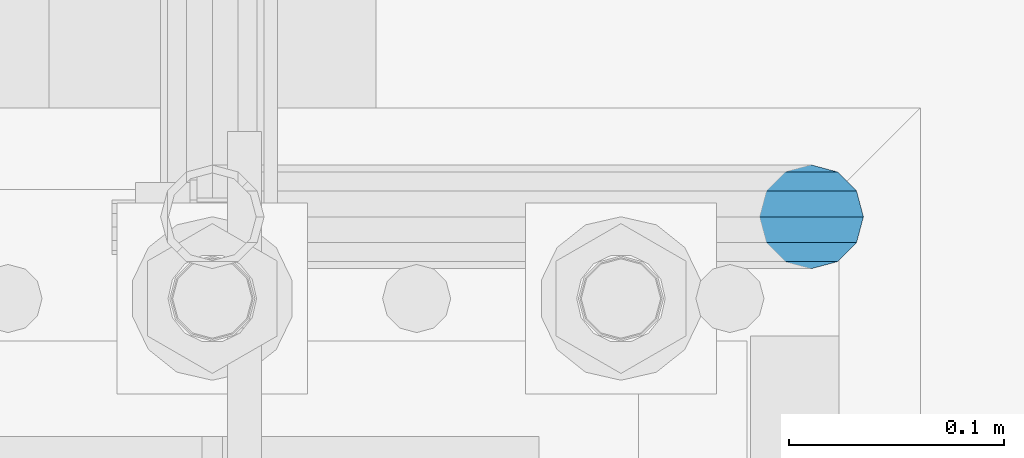
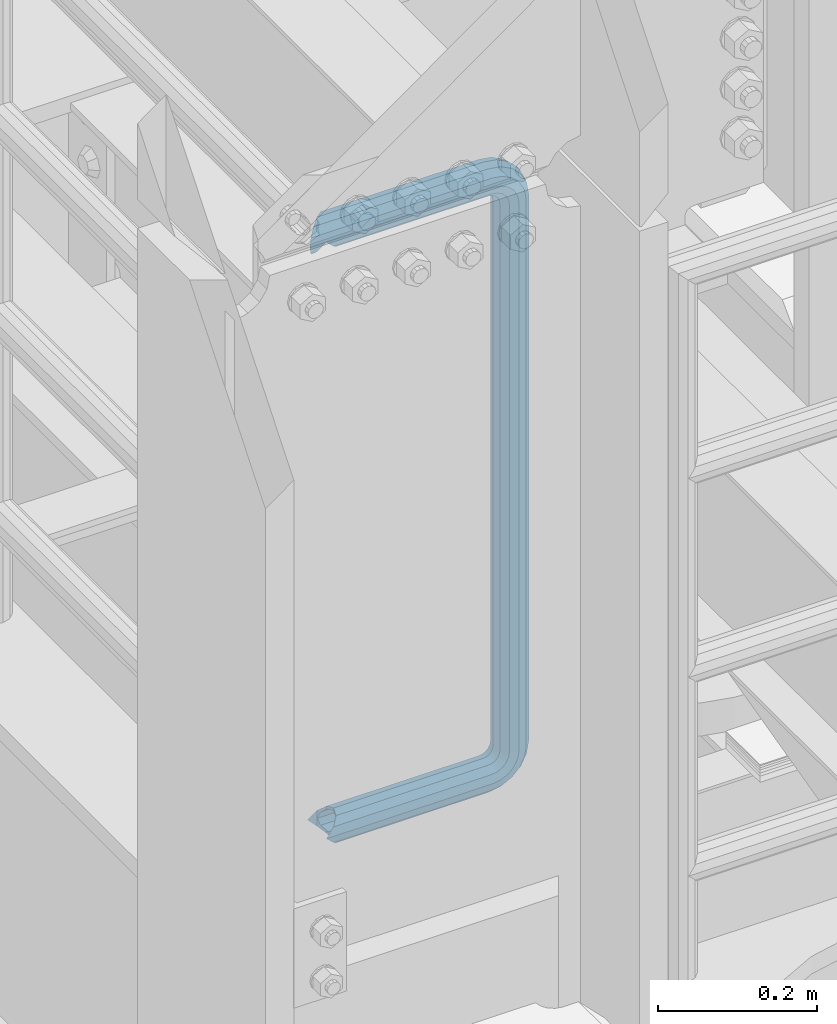
# One storey, part 957 of 1876: 1 beam, 1 element without a shape of its own.
"""IFC2X3 building model written with IfcOpenShell, lengths in millimetres."""

from ifc_helpers import new_model, si_unit, frame, origin_with_axes, place, context, subcontext, project, spatial, faceted_brep, material, type_object, element, aggregate, save


model = new_model("IFC2X3")

# Units and contexts
model_context = context("Model", 3, precision=1e-05, world=origin_with_axes())
body_context = subcontext(model_context, "Body", "Model", "MODEL_VIEW")
ifc_project = project(units=[si_unit("LENGTHUNIT", "METRE", prefix="MILLI"), si_unit("AREAUNIT", "SQUARE_METRE"), si_unit("VOLUMEUNIT", "CUBIC_METRE"), si_unit("MASSUNIT", "GRAM", prefix="KILO"), si_unit("TIMEUNIT", "SECOND"), si_unit("PLANEANGLEUNIT", "RADIAN"), si_unit("SOLIDANGLEUNIT", "STERADIAN"), si_unit("THERMODYNAMICTEMPERATUREUNIT", "DEGREE_CELSIUS"), si_unit("LUMINOUSINTENSITYUNIT", "LUMEN")], contexts=[model_context])

# Site, building, storey
site_placement = place(None, origin_with_axes())
site = spatial("IfcSite", under=ifc_project, at=site_placement, CompositionType="ELEMENT")
building_placement = place(site_placement, origin_with_axes())
building = spatial("IfcBuilding", under=site, at=building_placement, Name="Undefined", CompositionType="ELEMENT")
storey_placement = place(building_placement, origin_with_axes())
storey = spatial("IfcBuildingStorey", under=building, at=storey_placement, Name="Undefined", CompositionType="ELEMENT", Elevation=0.0)

# Assembly, beam
assembly_placement = place(storey_placement, origin_with_axes())
assembly = element("IfcElementAssembly", 1, at=assembly_placement, inside=storey, Name="RAIL", AssemblyPlace="NOTDEFINED", PredefinedType="RIGID_FRAME")
ifc_material = material()
beam_type = type_object("IfcBeamType", Name="PIPE1-1/2SCH40", PredefinedType="NOTDEFINED")
beam_placement = place(assembly_placement, frame((-5.00222085975111e-12, -4356.1, 14385.925), z_axis=(0.0, 0.0, 1.0), x_axis=(1.0, 0.0, 0.0)))
beam = element("IfcBeam", 2, at=beam_placement, type_object=beam_type, material=ifc_material, Name="RAIL", ObjectType="PIPE1-1/2SCH40", context=body_context, shape_type="Brep", body=[
    faceted_brep([(16.4810964966631, 16.4810964966564, -11.4500249345219), (16.481099754581, 16.4810997545774, -16.4810932387409), (20.8971929933249, 12.0650000000005, -20.8971929933177), (20.8971929933249, 12.0650000000005, -15.8661214311796), (0.0, -24.1299999999992, 0.0), (12.0650000000014, -20.8971929933186, 0.0), (12.0650000000064, -20.8971929933177, -12.0649999999987), (-12.0650000000096, -20.8971929933177, -12.0649999999987), (-12.0649999999986, -20.8971929933186, 0.0), (-16.481093238739, -16.4810932387427, -16.4810997545756), (-16.4810964966554, -16.4810964966618, -11.4500249345183), (-15.2545715621367, -17.7076214311801, -10.2235000000001), (-12.5151929933171, -20.4470000000001, 0.0), (12.5151929933249, -20.4470000000001, 0.0), (20.8971929933249, -12.0650000000005, -15.8661214311796), (20.8971929933249, -12.0650000000005, -20.8971929933177), (15.2545715621445, -17.7076214311801, -10.2235000000001), (24.1300000000063, 0.0, -20.4470000000001), (24.1300000000063, 0.0, -24.130000000001), (21.3906214311868, -10.2235000000001, -17.7076214311819), (21.3906214311868, 10.2235000000001, -17.7076214311819), (1.20714750983051e-12, 24.1299999999974, -914.399963378906), (12.0650000000014, 20.8971929933159, -926.464963378905), (12.0650000000014, 20.8971929933177, -902.334963378908), (12.0650000000014, -20.8971929933195, -902.334963378908), (12.0650000000014, -20.8971929933195, -926.464963378905), (1.52133659548828e-12, -24.130000000001, -914.399963378906), (20.8971929933199, -12.0650000000023, -893.502770385589), (20.8971929933199, -12.0650000000005, -898.533841947723), (15.2545715621378, -17.7076214311819, -904.176463378906), (12.5151929933181, -20.4470000000019, -914.399963378906), (15.2545715621376, -17.7076214311819, -924.623463378906), (20.8971929933199, -12.0650000000005, -930.26608481009), (20.8971929933199, -12.0650000000023, -935.297156372224), (24.1300000000014, -1.81898940354586e-12, -934.846963378906), (24.1300000000014, -1.81898940354586e-12, -938.529963378907), (21.3906214311813, -10.2235000000019, -932.107584810088), (21.3906214311823, 10.2234999999982, -932.107584810088), (20.8971929933199, 12.0650000000005, -930.266084810086), (20.8971929933199, 12.0649999999987, -935.297156372224), (15.2545715621413, 17.7076214311783, -924.623463378906), (12.5151929933216, 20.4469999999983, -914.399963378906), (15.2545715621411, 17.7076214311783, -904.176463378906), (20.8971929933199, 12.0650000000005, -898.533841947727), (20.8971929933199, 12.0649999999987, -893.502770385589), (21.3906214311822, 10.2234999999982, -896.692341947724), (24.1300000000014, 0.0, -893.952963378906), (24.1300000000014, 0.0, -890.269963378905), (21.3906214311814, -10.2235000000019, -896.692341947724), (241.299995422363, -20.8971929933177, 12.0649999999987), (241.299995422363, -24.1299999999992, 0.0), (253.073542436527, -24.1299999999992, -1.86474665447167), (256.801832473661, -20.8971929933177, 9.60975021462946), (241.299995422363, -12.0650000000005, 20.8971929933177), (259.531130206197, -12.0650000000005, 18.0096649141014), (241.299995422363, 0.0, 24.130000000001), (260.530122510796, 0.0, 21.084247083727), (241.299995422363, 12.0650000000005, 20.8971929933177), (259.531130206197, 12.0650000000005, 18.0096649141014), (241.299995422363, 20.8971929933177, 12.0649999999987), (256.801832473661, 20.8971929933177, 9.60975021462946), (241.299995422363, 24.1299999999992, 0.0), (253.073542436527, 24.1299999999992, -1.86474665447167), (241.299995422363, 20.8971929933177, -12.0649999999987), (249.345252399393, 20.8971929933177, -13.3392435235728), (241.299995422363, 12.0650000000005, -20.8971929933177), (246.615954666858, 12.0650000000005, -21.7391582230448), (241.299995422363, 0.0, -24.130000000001), (245.616962362259, 0.0, -24.8137403926739), (241.299995422363, -12.0650000000005, -20.8971929933177), (246.615954666858, -12.0650000000005, -21.7391582230448), (241.299995422363, -20.8971929933177, -12.0649999999987), (249.345252399393, -20.8971929933177, -13.3392435235728), (267.334993896485, 20.8971929933177, -38.0999984741211), (279.399993896485, 24.1299999999992, -38.0999984741211), (279.399993896484, 24.1299999999992, -876.299964904785), (267.334993896484, 20.8971929933177, -876.299964904785), (291.464993896486, 20.8971929933177, -38.0999984741211), (291.464993896484, 20.8971929933177, -876.299964904785), (300.297186889804, 12.0650000000005, -38.0999984741211), (300.297186889803, 12.0650000000005, -876.299964904785), (303.529993896486, 0.0, -38.0999984741211), (303.529993896484, 0.0, -876.299964904785), (300.297186889804, -12.0650000000005, -38.0999984741211), (300.297186889803, -12.0650000000005, -876.299964904785), (291.464993896486, -20.8971929933177, -38.0999984741211), (291.464993896484, -20.8971929933177, -876.299964904785), (279.399993896484, -24.1299999999992, -38.0999984741211), (279.399993896484, -24.1299999999992, -876.299964904785), (267.334993896485, -20.8971929933177, -38.0999984741211), (267.334993896484, -20.8971929933177, -876.299964904785), (258.502800903167, -12.0650000000005, -38.0999984741211), (258.502800903166, -12.0650000000005, -876.299964904785), (255.269993896485, 0.0, -38.0999984741211), (255.269993896484, 0.0, -876.299964904785), (258.502800903167, 12.0650000000005, -38.0999984741211), (258.502800903166, 12.0650000000005, -876.299964904785), (257.660835673438, 12.0650000000005, -881.615924149282), (254.586253503809, 0.0, -880.616931844681), (257.660835673438, -12.0650000000005, -881.615924149282), (266.06075037291, -20.8971929933177, -884.345221881817), (277.535247242011, -24.130000000001, -888.073511918952), (289.009744111112, -20.8971929933195, -891.801801956084), (297.409658810584, -12.0650000000005, -894.531099688622), (300.484240980214, 0.0, -895.53009199322), (297.409658810584, 12.0650000000005, -894.531099688622), (289.009744111112, 20.8971929933177, -891.801801956084), (277.535247242011, 24.1299999999992, -888.073511918952), (266.06075037291, 20.8971929933177, -884.345221881817), (241.299995422364, -1.81898940354586e-12, -938.529963378911), (241.299995422364, -12.0650000000005, -935.297156372228), (241.299995422364, -20.8971929933195, -926.464963378909), (241.299995422363, -24.130000000001, -914.399963378906), (241.299995422363, -20.8971929933195, -902.334963378908), (241.299995422363, -12.0650000000005, -893.502770385589), (241.299995422363, 0.0, -890.269963378909), (241.299995422364, 20.8971929933177, -926.464963378909), (241.299995422364, 12.0649999999987, -935.297156372228), (241.299995422364, 24.1299999999992, -914.39996337891), (241.299995422363, 20.8971929933177, -902.334963378908), (241.299995422363, 12.0649999999987, -893.502770385589), (260.530122510801, 0.0, -935.484210462637), (259.531130206202, 12.0649999999987, -932.409628293008), (259.531130206201, -12.0650000000005, -932.409628293008), (256.801832473666, -20.8971929933195, -924.009713593536), (253.07354243653, -24.130000000001, -912.535216724435), (249.345252399395, -20.8971929933195, -901.060719855333), (246.615954666859, -12.0650000000005, -892.660805155861), (245.61696236226, 0.0, -889.586222986232), (246.615954666859, 12.0649999999987, -892.660805155861), (249.345252399395, 20.8971929933177, -901.060719855333), (253.07354243653, 24.1299999999992, -912.535216724435), (256.801832473666, 20.8971929933177, -924.009713593536), (275.977674493594, 12.0649999999987, -924.029695422345), (270.786241706733, 20.8971929933177, -916.884301193139), (277.877870775644, 0.0, -926.645091230272), (275.977674493608, -12.0650000000005, -924.029695422334), (270.786241706733, -20.8971929933195, -916.884301193139), (263.694612637823, -24.130000000001, -907.123511156005), (256.602983568912, -20.8971929933195, -897.362721118872), (251.411550782037, -12.0650000000005, -890.21732688968), (249.511354500001, 0.0, -887.601931081743), (251.411550782037, 12.0650000000005, -890.21732688968), (256.602983568912, 20.8971929933177, -897.362721118872), (263.694612637823, 24.1299999999992, -907.123511156005), (281.884331710718, 20.8971929933177, -905.786211189152), (272.123541673585, 24.1299999999992, -898.694582120243), (289.029725939912, 12.0650000000005, -910.977643976028), (291.645121747852, 0.0, -912.877840258065), (289.029725939912, -12.0650000000005, -910.977643976028), (281.884331710718, -20.8971929933195, -905.786211189152), (272.123541673585, -24.130000000001, -898.694582120243), (262.362751636451, -20.8971929933195, -891.602953051333), (255.217357407258, -12.0650000000005, -886.411520264461), (252.601961599318, 0.0, -884.511323982424), (255.217357407258, 12.0650000000005, -886.411520264461), (262.362751636451, 20.8971929933177, -891.602953051333), (266.060750372911, 20.8971929933177, -30.0547414970897), (257.660835673439, 12.0650000000005, -32.7840392296275), (277.535247242011, 24.1299999999992, -26.3264514599541), (289.009744111112, 20.8971929933177, -22.5981614228222), (297.409658810584, 12.0650000000005, -19.8688636902843), (300.484240980213, 0.0, -18.8698713856866), (297.409658810584, -12.0650000000005, -19.8688636902843), (289.009744111112, -20.8971929933177, -22.5981614228222), (277.535247242011, -24.1299999999992, -26.3264514599541), (266.060750372911, -20.8971929933177, -30.0547414970897), (257.660835673439, -12.0650000000005, -32.7840392296275), (254.58625350381, 0.0, -33.7830315342253), (255.217357407257, 12.0650000000005, -27.9884431144455), (252.601961599318, 0.0, -29.8886393964822), (262.362751636451, 20.8971929933177, -22.7970103275729), (272.123541673583, 24.1299999999992, -15.7053812586601), (281.884331710716, 20.8971929933177, -8.61375218975081), (289.029725939909, 12.0650000000005, -3.42231940287456), (291.645121747848, 0.0, -1.52212312084157), (289.029725939909, -12.0650000000005, -3.42231940287456), (281.884331710716, -20.8971929933177, -8.61375218975081), (272.123541673583, -24.1299999999992, -15.7053812586601), (262.362751636451, -20.8971929933177, -22.7970103275729), (255.217357407257, -12.0650000000005, -27.9884431144455), (249.511354500002, 0.0, -26.7980322971671), (251.411550782037, -12.0650000000005, -24.1826364892258), (251.411550782037, 12.0650000000005, -24.1826364892258), (256.602983568912, 20.8971929933177, -17.037242260034), (263.694612637822, 24.1299999999992, -7.27645222290084), (270.786241706732, 20.8971929933177, 2.48433781423228), (275.977674493607, 12.0650000000005, 9.62973204342416), (277.877870775642, 0.0, 12.2451278513654), (275.977674493607, -12.0650000000005, 9.62973204342416), (270.786241706732, -20.8971929933177, 2.48433781423228), (263.694612637822, -24.1299999999992, -7.27645222290084), (256.602983568912, -20.8971929933177, -17.037242260034), (20.8971929933232, 20.8971929933177, -12.0649999999987), (24.1300000000047, 24.1299999999992, 0.0), (20.8971929933232, 20.8971929933177, 12.0649999999987), (12.0650000000041, 12.0650000000005, 20.8971929933177), (-1.45519152283669e-11, 0.0, 24.130000000001), (-12.0649999999951, -12.0650000000005, 20.8971929933177), (-20.8971929933141, -20.8971929933177, 12.0649999999987), (-24.1299999999956, -24.1299999999992, 0.0), (-20.8971929933141, -20.8971929933177, -12.0649999999987), (-17.7076214311755, -17.7076214311801, -10.2235000000001), (-20.4469999999956, -20.4470000000001, 0.0), (-17.7076214311755, -17.7076214311801, 10.2235000000001), (241.299995422363, -17.7076214311801, 10.2235000000001), (241.299995422363, -20.4470000000001, 0.0), (241.299995422363, -17.7076214311801, -10.2235000000001), (241.299995422363, -10.2235000000001, -17.7076214311819), (241.299995422363, 0.0, -20.4470000000001), (241.299995422363, 0.0, 20.4470000000001), (241.299995422363, -10.2235000000001, 17.7076214311819), (-10.2234999999955, -10.2235000000001, 17.7076214311819), (-1.45519152283669e-11, 0.0, 20.4470000000001), (241.299995422363, 10.2235000000001, 17.7076214311819), (10.2235000000046, 10.2235000000001, 17.7076214311819), (241.299995422363, 17.7076214311801, 10.2235000000001), (17.7076214311846, 17.7076214311801, 10.2235000000001), (241.299995422363, 20.4470000000001, 0.0), (20.4470000000047, 20.4470000000001, 0.0), (241.299995422363, 17.7076214311801, -10.2235000000001), (17.7076214311846, 17.7076214311801, -10.2235000000001), (241.299995422363, 10.2235000000001, -17.7076214311819), (258.545498388721, -10.2235000000001, 14.9762020957387), (256.23277767852, -17.7076214311801, 7.85837963987069), (253.073542436527, -20.4470000000001, -1.86474665447167), (249.914307194535, -17.7076214311801, -11.5878729488177), (247.601586484334, -10.2235000000001, -18.7056954046857), (246.755071952542, 0.0, -21.31099924316), (247.601586484334, 10.2235000000001, -18.7056954046857), (249.914307194535, 17.7076214311801, -11.5878729488177), (253.073542436527, 20.4470000000001, -1.86474665447167), (256.23277767852, 17.7076214311801, 7.85837963987069), (258.545498388721, 10.2235000000001, 14.9762020957387), (259.392012920513, 0.0, 17.5815059342131), (275.713057691449, 0.0, 9.26551826108334), (274.10289136825, -10.2235000000001, 7.04931444488102), (274.10289136825, 10.2235000000001, 7.04931444488102), (269.703835164635, 17.7076214311801, 0.994533019089431), (263.694612637822, 20.4470000000001, -7.27645222290084), (257.685390111009, 17.7076214311801, -15.5474374648911), (253.286333907394, 10.2235000000001, -21.6022188906827), (251.676167584195, 0.0, -23.818422706885), (253.286333907394, -10.2235000000001, -21.6022188906827), (257.685390111009, -17.7076214311801, -15.5474374648911), (263.694612637822, -20.4470000000001, -7.27645222290084), (269.703835164635, -17.7076214311801, 0.994533019089431), (286.449308341364, -10.2235000000001, -5.29710252823133), (280.394526915574, -17.7076214311801, -9.69615873184739), (288.665512157566, 0.0, -3.68693620503473), (286.449308341364, 10.2235000000001, -5.29710252823133), (280.394526915574, 17.7076214311801, -9.69615873184739), (272.123541673583, 20.4470000000001, -15.7053812586601), (263.852556431592, 17.7076214311801, -21.7146037854764), (257.797775005802, 10.2235000000001, -26.1136599890888), (255.581571189601, 0.0, -27.723826312289), (257.797775005802, -10.2235000000001, -26.1136599890888), (263.852556431592, -17.7076214311801, -21.7146037854764), (272.123541673583, -20.4470000000001, -15.7053812586601), (287.258373536355, -17.7076214311801, -23.1672162179639), (277.535247242011, -20.4470000000001, -26.3264514599541), (294.376195992223, -10.2235000000001, -20.8544955077632), (296.981499830698, 0.0, -20.00798097597), (294.376195992223, 10.2235000000001, -20.8544955077632), (287.258373536355, 17.7076214311801, -23.1672162179639), (277.535247242011, 20.4470000000001, -26.3264514599541), (267.812120947668, 17.7076214311801, -29.485686701948), (260.6942984918, 10.2235000000001, -31.7984074121487), (258.088994653325, 0.0, -32.6449219439419), (260.6942984918, -10.2235000000001, -31.7984074121487), (267.812120947668, -17.7076214311801, -29.485686701948), (279.399993896484, -20.4470000000001, -38.0999984741211), (269.176493896485, -17.7076214311801, -38.0999984741211), (289.623493896486, -17.7076214311801, -38.0999984741211), (297.107615327666, -10.2235000000001, -38.0999984741211), (299.846993896486, 0.0, -38.0999984741211), (297.107615327666, 10.2235000000001, -38.0999984741211), (289.623493896486, 17.7076214311801, -38.0999984741211), (279.399993896485, 20.4470000000001, -38.0999984741211), (269.176493896485, 17.7076214311801, -38.0999984741211), (261.692372465305, 10.2235000000001, -38.0999984741211), (258.952993896485, 0.0, -38.0999984741211), (261.692372465305, -10.2235000000001, -38.0999984741211), (269.176493896484, -17.7076214311801, -876.299964904785), (261.692372465304, -10.2235000000001, -876.299964904785), (258.952993896484, 0.0, -876.299964904785), (261.692372465304, 10.2235000000001, -876.299964904785), (269.176493896484, 17.7076214311801, -876.299964904785), (279.399993896484, 20.4470000000001, -876.299964904785), (289.623493896484, 17.7076214311801, -876.299964904785), (297.107615327665, 10.2235000000001, -876.299964904785), (299.846993896484, 0.0, -876.299964904785), (297.107615327665, -10.2235000000001, -876.299964904785), (289.623493896484, -17.7076214311801, -876.299964904785), (279.399993896484, -20.4470000000001, -876.299964904785), (277.535247242011, -20.4470000000001, -888.073511918952), (267.812120947667, -17.7076214311801, -884.914276676958), (260.694298491799, -10.2235000000001, -882.601555966758), (258.088994653324, 0.0, -881.755041434964), (260.694298491799, 10.2235000000001, -882.601555966758), (267.812120947668, 17.7076214311801, -884.914276676958), (277.535247242011, 20.4470000000001, -888.073511918952), (287.258373536355, 17.7076214311801, -891.232747160942), (294.376195992223, 10.2235000000001, -893.545467871143), (296.981499830699, 0.0, -894.391982402936), (294.376195992223, -10.2235000000001, -893.545467871143), (287.258373536355, -17.7076214311801, -891.232747160942), (280.394526915577, -17.7076214311801, -904.703804647055), (272.123541673585, -20.4470000000001, -898.694582120243), (286.449308341367, -10.2235000000001, -909.102860850671), (288.665512157569, 0.0, -910.713027173868), (286.449308341367, 10.2235000000001, -909.102860850671), (280.394526915577, 17.7076214311801, -904.703804647055), (272.123541673585, 20.4470000000001, -898.694582120243), (263.852556431593, 17.7076214311801, -892.68535959343), (257.797775005802, 10.2235000000001, -888.286303389817), (255.581571189601, 0.0, -886.676137066617), (257.797775005802, -10.2235000000001, -888.286303389817), (263.852556431593, -17.7076214311801, -892.68535959343), (263.694612637823, -20.4470000000001, -907.123511156005), (257.685390111009, -17.7076214311801, -898.852525914015), (269.703835164636, -17.7076214311801, -915.394496397999), (274.102891368238, -10.2235000000001, -921.449277823798), (275.71305769145, 0.0, -923.66548163999), (274.102891368251, 10.2235000000001, -921.449277823787), (269.703835164636, 17.7076214311801, -915.394496397999), (263.694612637823, 20.4470000000001, -907.123511156005), (257.685390111009, 17.7076214311801, -898.852525914015), (253.286333907394, 10.2235000000001, -892.797744488227), (251.676167584195, 0.0, -890.581540672025), (253.286333907394, -10.2235000000001, -892.797744488227), (249.914307194537, -17.7076214311801, -902.812090430092), (247.601586484335, -10.2235000000001, -895.694267974224), (253.07354243653, -20.4470000000001, -912.535216724435), (256.232777678524, -17.7076214311819, -922.258343018777), (258.545498388725, -10.2235000000001, -929.376165474645), (259.392012920517, 0.0, -931.981469313119), (258.545498388725, 10.2235000000001, -929.376165474645), (256.232777678524, 17.7076214311801, -922.258343018777), (253.07354243653, 20.4470000000001, -912.535216724435), (249.914307194537, 17.7076214311801, -902.812090430092), (247.601586484335, 10.2235000000001, -895.694267974224), (246.755071952543, 0.0, -893.088964135746), (241.299995422363, -10.2235000000001, -896.692341947728), (241.299995422363, 0.0, -893.95296337891), (241.299995422363, -17.7076214311819, -904.17646337891), (241.299995422363, -20.4470000000001, -914.399963378906), (241.299995422364, -17.7076214311819, -924.62346337891), (241.299995422364, -10.2235000000001, -932.107584810088), (241.299995422364, -1.81898940354586e-12, -934.84696337891), (241.299995422364, 10.2234999999982, -932.107584810088), (241.299995422364, 17.7076214311801, -924.62346337891), (241.299995422364, 20.4470000000001, -914.39996337891), (241.299995422363, 17.7076214311801, -904.17646337891), (241.299995422363, 10.2235000000001, -896.692341947728)], [[[0, 1, 2, 3]], [[4, 5, 6]], [[7, 8, 4]], [[9, 10, 11, 12, 8, 7]], [[13, 5, 4, 8, 12]], [[14, 15, 6, 5, 13, 16]], [[17, 18, 15, 14, 19]], [[20, 3, 2, 18, 17]], [[21, 22, 23]], [[24, 25, 26]], [[27, 28, 29, 30, 31, 32, 33, 25, 24]], [[34, 35, 33, 32, 36]], [[37, 38, 39, 35, 34]], [[23, 22, 39, 38, 40, 41, 42, 43, 44]], [[44, 43, 45, 46, 47]], [[47, 46, 48, 28, 27]], [[49, 50, 51, 52]], [[53, 49, 52, 54]], [[55, 53, 54, 56]], [[57, 55, 56, 58]], [[59, 57, 58, 60]], [[61, 59, 60, 62]], [[63, 61, 62, 64]], [[65, 63, 64, 66]], [[67, 65, 66, 68]], [[69, 67, 68, 70]], [[71, 69, 70, 72]], [[73, 74, 75, 76]], [[74, 77, 78, 75]], [[77, 79, 80, 78]], [[79, 81, 82, 80]], [[81, 83, 84, 82]], [[83, 85, 86, 84]], [[85, 87, 88, 86]], [[87, 89, 90, 88]], [[89, 91, 92, 90]], [[91, 93, 94, 92]], [[93, 95, 96, 94]], [[94, 96, 97, 98]], [[92, 94, 98, 99]], [[90, 92, 99, 100]], [[88, 90, 100, 101]], [[86, 88, 101, 102]], [[84, 86, 102, 103]], [[82, 84, 103, 104]], [[80, 82, 104, 105]], [[78, 80, 105, 106]], [[75, 78, 106, 107]], [[76, 75, 107, 108]], [[109, 110, 33, 35]], [[110, 111, 25, 33]], [[111, 112, 26, 25]], [[112, 113, 24, 26]], [[113, 114, 27, 24]], [[114, 115, 47, 27]], [[116, 117, 39, 22]], [[118, 116, 22, 21]], [[119, 118, 21, 23]], [[120, 119, 23, 44]], [[115, 120, 44, 47]], [[117, 109, 35, 39]], [[121, 109, 117, 122]], [[123, 110, 109, 121]], [[124, 111, 110, 123]], [[125, 112, 111, 124]], [[126, 113, 112, 125]], [[127, 114, 113, 126]], [[128, 115, 114, 127]], [[129, 120, 115, 128]], [[130, 119, 120, 129]], [[131, 118, 119, 130]], [[132, 116, 118, 131]], [[122, 117, 116, 132]], [[133, 122, 132, 134]], [[135, 121, 122, 133]], [[136, 123, 121, 135]], [[137, 124, 123, 136]], [[138, 125, 124, 137]], [[139, 126, 125, 138]], [[140, 127, 126, 139]], [[141, 128, 127, 140]], [[142, 129, 128, 141]], [[143, 130, 129, 142]], [[144, 131, 130, 143]], [[134, 132, 131, 144]], [[145, 134, 144, 146]], [[147, 133, 134, 145]], [[148, 135, 133, 147]], [[149, 136, 135, 148]], [[150, 137, 136, 149]], [[151, 138, 137, 150]], [[152, 139, 138, 151]], [[153, 140, 139, 152]], [[154, 141, 140, 153]], [[155, 142, 141, 154]], [[156, 143, 142, 155]], [[146, 144, 143, 156]], [[107, 146, 156, 108]], [[106, 145, 146, 107]], [[105, 147, 145, 106]], [[104, 148, 147, 105]], [[103, 149, 148, 104]], [[102, 150, 149, 103]], [[101, 151, 150, 102]], [[100, 152, 151, 101]], [[99, 153, 152, 100]], [[98, 154, 153, 99]], [[97, 155, 154, 98]], [[108, 156, 155, 97]], [[96, 76, 108, 97]], [[95, 73, 76, 96]], [[157, 73, 95, 158]], [[159, 74, 73, 157]], [[160, 77, 74, 159]], [[161, 79, 77, 160]], [[162, 81, 79, 161]], [[163, 83, 81, 162]], [[164, 85, 83, 163]], [[165, 87, 85, 164]], [[166, 89, 87, 165]], [[167, 91, 89, 166]], [[168, 93, 91, 167]], [[158, 95, 93, 168]], [[169, 158, 168, 170]], [[171, 157, 158, 169]], [[172, 159, 157, 171]], [[173, 160, 159, 172]], [[174, 161, 160, 173]], [[175, 162, 161, 174]], [[176, 163, 162, 175]], [[177, 164, 163, 176]], [[178, 165, 164, 177]], [[179, 166, 165, 178]], [[180, 167, 166, 179]], [[170, 168, 167, 180]], [[181, 170, 180, 182]], [[183, 169, 170, 181]], [[184, 171, 169, 183]], [[185, 172, 171, 184]], [[186, 173, 172, 185]], [[187, 174, 173, 186]], [[188, 175, 174, 187]], [[189, 176, 175, 188]], [[190, 177, 176, 189]], [[191, 178, 177, 190]], [[192, 179, 178, 191]], [[182, 180, 179, 192]], [[70, 182, 192, 72]], [[68, 181, 182, 70]], [[66, 183, 181, 68]], [[64, 184, 183, 66]], [[62, 185, 184, 64]], [[60, 186, 185, 62]], [[58, 187, 186, 60]], [[56, 188, 187, 58]], [[54, 189, 188, 56]], [[52, 190, 189, 54]], [[51, 191, 190, 52]], [[72, 192, 191, 51]], [[50, 71, 72, 51]], [[71, 50, 4, 6]], [[69, 71, 6, 15]], [[67, 69, 15, 18]], [[65, 67, 18, 2]], [[193, 63, 65, 2, 1]], [[61, 63, 193, 194]], [[59, 61, 194, 195]], [[57, 59, 195, 196]], [[55, 57, 196, 197]], [[53, 55, 197, 198]], [[49, 53, 198, 199]], [[4, 50, 49, 199, 200]], [[200, 201, 7, 4]], [[201, 9, 7]], [[202, 11, 10]], [[202, 203, 12, 11]], [[203, 204, 205, 206, 13, 12]], [[206, 207, 16, 13]], [[16, 207, 208, 19, 14]], [[208, 209, 17, 19]], [[210, 211, 212, 213]], [[214, 210, 213, 215]], [[216, 214, 215, 217]], [[218, 216, 217, 219]], [[220, 218, 219, 221]], [[222, 220, 221, 0, 3, 20]], [[209, 222, 20, 17]], [[221, 219, 217, 215, 213, 212, 204, 203, 202, 10, 9, 201, 200, 199, 198, 197, 196, 195, 194, 193, 1, 0]], [[211, 205, 204, 212]], [[205, 211, 223, 224]], [[206, 205, 224, 225]], [[207, 206, 225, 226]], [[208, 207, 226, 227]], [[209, 208, 227, 228]], [[222, 209, 228, 229]], [[220, 222, 229, 230]], [[218, 220, 230, 231]], [[216, 218, 231, 232]], [[214, 216, 232, 233]], [[210, 214, 233, 234]], [[211, 210, 234, 223]], [[234, 235, 236, 223]], [[233, 237, 235, 234]], [[232, 238, 237, 233]], [[231, 239, 238, 232]], [[230, 240, 239, 231]], [[229, 241, 240, 230]], [[228, 242, 241, 229]], [[227, 243, 242, 228]], [[226, 244, 243, 227]], [[225, 245, 244, 226]], [[224, 246, 245, 225]], [[223, 236, 246, 224]], [[236, 247, 248, 246]], [[235, 249, 247, 236]], [[237, 250, 249, 235]], [[238, 251, 250, 237]], [[239, 252, 251, 238]], [[240, 253, 252, 239]], [[241, 254, 253, 240]], [[242, 255, 254, 241]], [[243, 256, 255, 242]], [[244, 257, 256, 243]], [[245, 258, 257, 244]], [[246, 248, 258, 245]], [[248, 259, 260, 258]], [[247, 261, 259, 248]], [[249, 262, 261, 247]], [[250, 263, 262, 249]], [[251, 264, 263, 250]], [[252, 265, 264, 251]], [[253, 266, 265, 252]], [[254, 267, 266, 253]], [[255, 268, 267, 254]], [[256, 269, 268, 255]], [[257, 270, 269, 256]], [[258, 260, 270, 257]], [[260, 271, 272, 270]], [[259, 273, 271, 260]], [[261, 274, 273, 259]], [[262, 275, 274, 261]], [[263, 276, 275, 262]], [[264, 277, 276, 263]], [[265, 278, 277, 264]], [[266, 279, 278, 265]], [[267, 280, 279, 266]], [[268, 281, 280, 267]], [[269, 282, 281, 268]], [[270, 272, 282, 269]], [[282, 272, 283, 284]], [[281, 282, 284, 285]], [[280, 281, 285, 286]], [[279, 280, 286, 287]], [[278, 279, 287, 288]], [[277, 278, 288, 289]], [[276, 277, 289, 290]], [[275, 276, 290, 291]], [[274, 275, 291, 292]], [[273, 274, 292, 293]], [[271, 273, 293, 294]], [[272, 271, 294, 283]], [[283, 294, 295, 296]], [[284, 283, 296, 297]], [[285, 284, 297, 298]], [[286, 285, 298, 299]], [[287, 286, 299, 300]], [[288, 287, 300, 301]], [[289, 288, 301, 302]], [[290, 289, 302, 303]], [[291, 290, 303, 304]], [[292, 291, 304, 305]], [[293, 292, 305, 306]], [[294, 293, 306, 295]], [[306, 307, 308, 295]], [[305, 309, 307, 306]], [[304, 310, 309, 305]], [[303, 311, 310, 304]], [[302, 312, 311, 303]], [[301, 313, 312, 302]], [[300, 314, 313, 301]], [[299, 315, 314, 300]], [[298, 316, 315, 299]], [[297, 317, 316, 298]], [[296, 318, 317, 297]], [[295, 308, 318, 296]], [[308, 319, 320, 318]], [[307, 321, 319, 308]], [[309, 322, 321, 307]], [[310, 323, 322, 309]], [[311, 324, 323, 310]], [[312, 325, 324, 311]], [[313, 326, 325, 312]], [[314, 327, 326, 313]], [[315, 328, 327, 314]], [[316, 329, 328, 315]], [[317, 330, 329, 316]], [[318, 320, 330, 317]], [[320, 331, 332, 330]], [[319, 333, 331, 320]], [[321, 334, 333, 319]], [[322, 335, 334, 321]], [[323, 336, 335, 322]], [[324, 337, 336, 323]], [[325, 338, 337, 324]], [[326, 339, 338, 325]], [[327, 340, 339, 326]], [[328, 341, 340, 327]], [[329, 342, 341, 328]], [[330, 332, 342, 329]], [[332, 343, 344, 342]], [[331, 345, 343, 332]], [[333, 346, 345, 331]], [[334, 347, 346, 333]], [[335, 348, 347, 334]], [[336, 349, 348, 335]], [[337, 350, 349, 336]], [[338, 351, 350, 337]], [[339, 352, 351, 338]], [[340, 353, 352, 339]], [[341, 354, 353, 340]], [[342, 344, 354, 341]], [[354, 344, 46, 45]], [[42, 353, 354, 45, 43]], [[352, 353, 42, 41]], [[351, 352, 41, 40]], [[350, 351, 40, 38, 37]], [[349, 350, 37, 34]], [[348, 349, 34, 36]], [[31, 347, 348, 36, 32]], [[346, 347, 31, 30]], [[345, 346, 30, 29]], [[343, 345, 29, 28, 48]], [[344, 343, 48, 46]]]),
])
aggregate(assembly, [beam])

save(model, "model.ifc")
